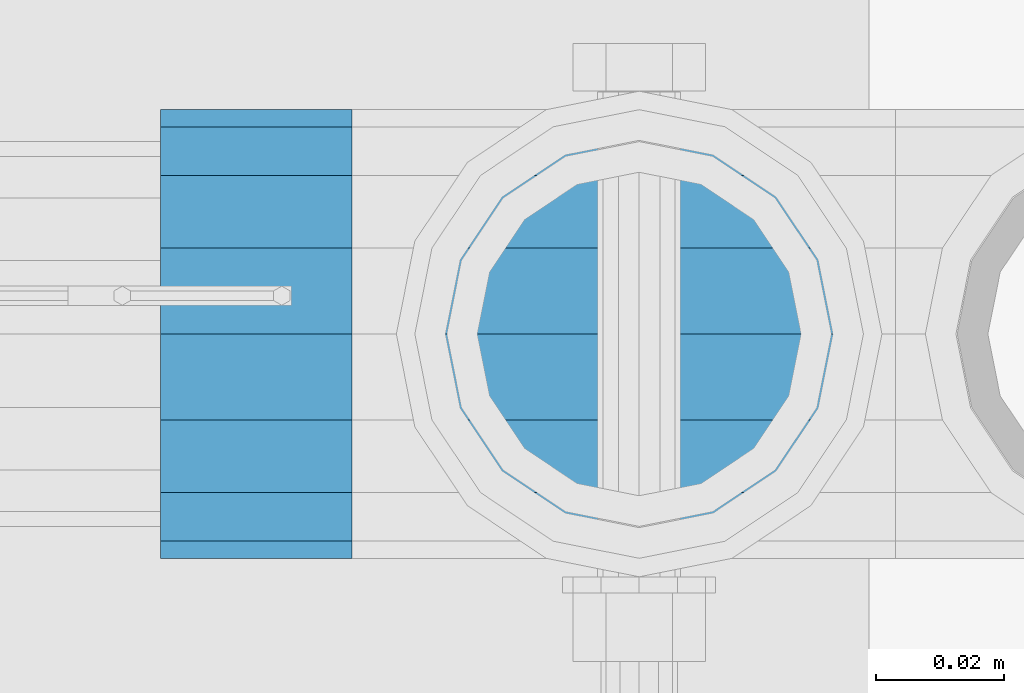
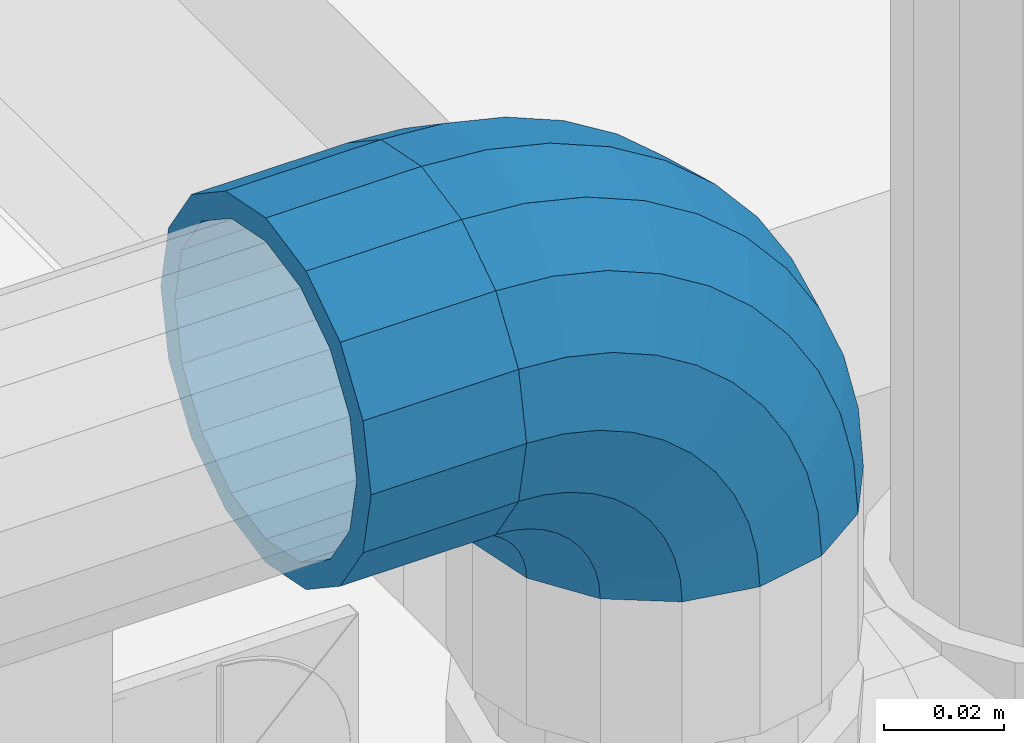
# One storey, part 173 of 247: 1 beam, 1 member.
"""IFC2X3 building model written with IfcOpenShell, lengths in millimetres."""

import ifcopenshell
import ifcopenshell.guid

model = None  # the IFC model being written
_history = None  # IfcOwnerHistory: only IFC2X3 demands one
_inside = {}  # id of a spatial element -> (the spatial element, [elements in it])
_under = {}  # id of a project, library or spatial element -> (it, [spatial elements below it])
_declared = {}  # id of a project -> (the project, [libraries it declares])
_typed = {}  # id of a type object -> (the type object, [elements of that type])
_made_of = {}  # id of a material, layer set ... -> (it, [elements and type objects made of it])


def new_model(schema):
    """Start an empty IFC model of exactly this schema.

    Asked for "IFC4X3", IfcOpenShell would pick the latest addendum, in which some entities
    have other attributes; the version numbers below select the first issue.
    IFC2X3 requires an IfcOwnerHistory on every rooted entity: one is made here for all.
    """
    global model, _history
    if schema == "IFC4X3":
        model = ifcopenshell.file(schema_version=(4, 3, 0, 0))
    else:
        model = ifcopenshell.file(schema=schema)
    _inside.clear()
    _under.clear()
    _declared.clear()
    _typed.clear()
    _made_of.clear()
    _history = None
    if model.schema == "IFC2X3":
        org = make("IfcOrganization", Name="unknown")
        user = make(
            "IfcPersonAndOrganization",
            ThePerson=make("IfcPerson", FamilyName="unknown"),
            TheOrganization=org,
        )
        app = make(
            "IfcApplication",
            ApplicationDeveloper=org,
            Version="unknown",
            ApplicationFullName="unknown",
            ApplicationIdentifier="unknown",
        )
        _history = make(
            "IfcOwnerHistory",
            OwningUser=user,
            OwningApplication=app,
            ChangeAction="ADDED",
            CreationDate=0,
        )
    return model


def make(cls, **values):
    """One entity of the class cls with the attributes given. An attribute that is None is left unset."""
    return model.create_entity(
        cls, **{name: value for name, value in values.items() if value is not None}
    )


def rooted(cls, **values):
    """An entity with a GlobalId (a new one), such as an element, a storey or a relation."""
    return make(cls, GlobalId=ifcopenshell.guid.new(), OwnerHistory=_history, **values)


def si_unit(unit_type, name, prefix=None):
    """IfcSIUnit, for example si_unit("LENGTHUNIT", "METRE", prefix="MILLI")."""
    return make("IfcSIUnit", UnitType=unit_type, Prefix=prefix, Name=name)


def assignment(units):
    """IfcUnitAssignment: the units of a project."""
    return None if units is None else make("IfcUnitAssignment", Units=units)


def point(xyz):
    """IfcCartesianPoint."""
    return None if xyz is None else make("IfcCartesianPoint", Coordinates=xyz)


def direction(xyz):
    """IfcDirection."""
    return None if xyz is None else make("IfcDirection", DirectionRatios=xyz)


def frame(location, z_axis=None, x_axis=None):
    """IfcAxis2Placement3D, a coordinate frame: its origin and axes. An axis left out is left unset."""
    return make(
        "IfcAxis2Placement3D",
        Location=point(location),
        Axis=direction(z_axis),
        RefDirection=direction(x_axis),
    )


def origin_with_axes():
    """The frame at (0, 0, 0) with the z axis (0, 0, 1) and the x axis (1, 0, 0) written out."""
    return frame((0.0, 0.0, 0.0), z_axis=(0.0, 0.0, 1.0), x_axis=(1.0, 0.0, 0.0))


def place(relative_to, where):
    """IfcLocalPlacement: puts the frame where relative to a parent placement (None: the world)."""
    return make(
        "IfcLocalPlacement", PlacementRelTo=relative_to, RelativePlacement=where
    )


def context(
    kind, dimensions, precision=None, world=None, true_north=None, identifier=None
):
    """IfcGeometricRepresentationContext, for example the 3D "Model" context."""
    return make(
        "IfcGeometricRepresentationContext",
        ContextIdentifier=identifier,
        ContextType=kind,
        CoordinateSpaceDimension=dimensions,
        Precision=precision,
        WorldCoordinateSystem=world,
        TrueNorth=true_north,
    )


def subcontext(parent, identifier, kind, view, scale=None):
    """IfcGeometricRepresentationSubContext, for example "Body" below "Model"."""
    return make(
        "IfcGeometricRepresentationSubContext",
        ContextIdentifier=identifier,
        ContextType=kind,
        ParentContext=parent,
        TargetScale=scale,
        TargetView=view,
    )


def project(units=None, contexts=None):
    """IfcProject with its units and contexts."""
    return rooted(
        "IfcProject",
        Name="project",
        RepresentationContexts=contexts,
        UnitsInContext=assignment(units),
    )


def spatial(cls, under=None, at=None, **own):
    """A site, building, storey or space (cls), placed at a placement, below another one or the project."""
    s = rooted(cls, ObjectPlacement=at, **own)
    if under is not None:
        _under.setdefault(under.id(), (under, []))[1].append(s)
    return s


def faces_of(points, faces, orient=None, outer=None):
    """IfcFace entities. A face is a list of loops; a loop is a list of indices into points, from 0.

    orient and outer hold one flag for each loop. By default every Orientation is true, the
    first loop of a face is its IfcFaceOuterBound and the others are IfcFaceBound.
    """
    made = []
    for i, loops in enumerate(faces):
        bounds = []
        for j, loop in enumerate(loops):
            is_outer = j == 0 if outer is None else outer[i][j]
            bounds.append(
                make(
                    "IfcFaceOuterBound" if is_outer else "IfcFaceBound",
                    Bound=make("IfcPolyLoop", Polygon=[points[k] for k in loop]),
                    Orientation=True if orient is None else orient[i][j],
                )
            )
        made.append(make("IfcFace", Bounds=bounds))
    return made


def faceted_brep(points, faces, orient=None, outer=None, voids=None):
    """IfcFacetedBrep: a solid bounded by flat faces; with voids (closed shells), ...WithVoids."""
    shared = [point(p) for p in points]
    hull = make("IfcClosedShell", CfsFaces=faces_of(shared, faces, orient, outer))
    if voids is None:
        return make("IfcFacetedBrep", Outer=hull)
    return make(
        "IfcFacetedBrepWithVoids",
        Outer=hull,
        Voids=[
            make(cls, CfsFaces=faces_of(shared, fs, o, b)) for cls, fs, o, b in voids
        ],
    )


def shape(context_of_items, identifier, shape_type, items):
    """IfcShapeRepresentation: the items that make up one representation, for example the "Body"."""
    return make(
        "IfcShapeRepresentation",
        ContextOfItems=context_of_items,
        RepresentationIdentifier=identifier,
        RepresentationType=shape_type,
        Items=items,
    )


def material(Name=None, Category=None):
    """IfcMaterial."""
    return make("IfcMaterial", Name=Name, Category=Category)


def made_of(thing, what):
    """Note that an element or type object is made of a material, layer set ...; save() writes the relation."""
    if what is not None:
        _made_of.setdefault(what.id(), (what, []))[1].append(thing)
    return thing


def type_object(cls, material=None, **own):
    """A type object (cls), such as IfcWallType, which elements share."""
    return made_of(rooted(cls, **own), material)


def element(
    cls,
    number,
    at=None,
    inside=None,
    cuts=None,
    type_object=None,
    material=None,
    context=None,
    identifier="Body",
    shape_type=None,
    held_by="IfcProductDefinitionShape",
    body=None,
    shapes=None,
    **own,
):
    """One element of the class cls, such as IfcWall. Its Tag is "e" and its number.

    at: its placement. inside: the storey or other place that contains it. cuts: it is an
    opening in that element (IfcRelVoidsElement). A single representation is given by context,
    identifier, shape_type and body (its items); several are given by shapes. held_by: the class
    of the entity that holds the representations. save() writes the other relations.
    """
    e = rooted(cls, Tag="e%d" % number, ObjectPlacement=at, **own)
    if body is not None:
        shapes = [shape(context, identifier, shape_type, body)]
    if shapes is not None:
        e.Representation = make(held_by, Representations=shapes)
    if inside is not None:
        _inside.setdefault(inside.id(), (inside, []))[1].append(e)
    if cuts is not None:
        rooted(
            "IfcRelVoidsElement", RelatingBuildingElement=cuts, RelatedOpeningElement=e
        )
    if type_object is not None:
        _typed.setdefault(type_object.id(), (type_object, []))[1].append(e)
    return made_of(e, material)


def aggregate(whole, parts):
    """IfcRelAggregates: a whole, such as a stair, and the parts it consists of."""
    return rooted("IfcRelAggregates", RelatingObject=whole, RelatedObjects=parts)


def save(model, path):
    """Write the relations noted so far, then the file.

    IfcRelAggregates (storeys below a building ...), IfcRelContainedInSpatialStructure (elements
    in a storey), IfcRelDefinesByType, IfcRelAssociatesMaterial and IfcRelDeclares: one each for
    every whole, place, type object, material and project.
    """
    for whole, parts in _under.values():
        aggregate(whole, parts)
    for where, things in _inside.values():
        rooted(
            "IfcRelContainedInSpatialStructure",
            RelatedElements=things,
            RelatingStructure=where,
        )
    for kind, things in _typed.values():
        rooted("IfcRelDefinesByType", RelatedObjects=things, RelatingType=kind)
    for what, things in _made_of.values():
        rooted("IfcRelAssociatesMaterial", RelatedObjects=things, RelatingMaterial=what)
    for by, libraries in _declared.values():
        rooted("IfcRelDeclares", RelatingContext=by, RelatedDefinitions=libraries)
    model.write(path)


model = new_model("IFC2X3")

# Units and contexts
model_context = context("Model", 3, precision=1e-05, world=origin_with_axes())
body_context = subcontext(model_context, "Body", "Model", "MODEL_VIEW")
ifc_project = project(units=[si_unit("LENGTHUNIT", "METRE", prefix="MILLI"), si_unit("AREAUNIT", "SQUARE_METRE"), si_unit("VOLUMEUNIT", "CUBIC_METRE"), si_unit("MASSUNIT", "GRAM", prefix="KILO"), si_unit("TIMEUNIT", "SECOND"), si_unit("PLANEANGLEUNIT", "RADIAN"), si_unit("SOLIDANGLEUNIT", "STERADIAN"), si_unit("THERMODYNAMICTEMPERATUREUNIT", "DEGREE_CELSIUS"), si_unit("LUMINOUSINTENSITYUNIT", "LUMEN")], contexts=[model_context])

# Site, building, storey
site_placement = place(None, origin_with_axes())
site = spatial("IfcSite", under=ifc_project, at=site_placement, CompositionType="ELEMENT")
building_placement = place(site_placement, origin_with_axes())
building = spatial("IfcBuilding", under=site, at=building_placement, Name="Standard", CompositionType="ELEMENT")
storey_placement = place(building_placement, origin_with_axes())
storey = spatial("IfcBuildingStorey", under=building, at=storey_placement, Name="Undefined", CompositionType="ELEMENT", Elevation=0.0)

# Beam
ifc_material = material(Name="Misc_Undefined")
beam_type = type_object("IfcBeamType", PredefinedType="NOTDEFINED")
beam_placement = place(storey_placement, frame((16176.0, 7664.5, 969.85), z_axis=(0.0, 0.0, 1.0), x_axis=(-1.0, 0.0, 0.0)))
element("IfcBeam", 1, at=beam_placement, inside=storey, type_object=beam_type, material=ifc_material, context=body_context, shape_type="Brep", body=[
    faceted_brep([(0.0, -30.3500000000004, 0.0), (0.0, -28.0397438117179, 11.6144421722802), (30.0, -28.0397438117179, 11.6144421722805), (30.0, -30.3500000000004, 0.0), (0.0, -21.4606908090118, 21.4606908090118), (30.0, -21.4606908090118, 21.4606908090117), (0.0, -11.6144421722802, 28.0397438117179), (30.0, -11.6144421722802, 28.0397438117175), (0.0, 0.0, 30.3500000000004), (30.0, 0.0, 30.35), (0.0, 11.6144421722802, 28.0397438117179), (30.0, 11.6144421722802, 28.0397438117175), (0.0, 21.4606908090118, 21.4606908090118), (30.0, 21.4606908090118, 21.4606908090117), (0.0, 28.0397438117179, 11.6144421722802), (30.0, 28.0397438117179, 11.6144421722805), (0.0, 30.3500000000004, 0.0), (30.0, 30.3500000000004, 0.0), (0.0, 28.0397438117179, -11.6144421722802), (30.0, 28.0397438117179, -11.6144421722805), (0.0, 21.4606908090118, -21.4606908090118), (30.0, 21.4606908090118, -21.4606908090117), (0.0, 11.6144421722802, -28.0397438117179), (30.0, 11.6144421722802, -28.0397438117175), (0.0, 0.0, -30.3500000000004), (30.0, 0.0, -30.35), (0.0, -11.6144421722802, -28.0397438117179), (30.0, -11.6144421722802, -28.0397438117175), (0.0, -21.4606908090118, -21.4606908090118), (30.0, -21.4606908090118, -21.4606908090117), (0.0, -28.0397438117179, -11.6144421722802), (30.0, -28.0397438117179, -11.6144421722805), (0.0, -35.1499999999996, 0.0), (0.0, -32.4743655677721, -13.4513226476338), (30.0, -32.4743655677721, -13.4513226476329), (30.0, -35.1499999999996, 0.0), (0.0, -24.8548033587067, -24.8548033587067), (30.0, -24.8548033587067, -24.8548033587072), (0.0, -13.4513226476329, -32.4743655677721), (30.0, -13.4513226476329, -32.4743655677717), (0.0, 0.0, -35.1499999999996), (30.0, 0.0, -35.15), (0.0, 13.4513226476329, -32.4743655677721), (30.0, 13.4513226476329, -32.4743655677717), (0.0, 24.8548033587067, -24.8548033587067), (30.0, 24.8548033587067, -24.8548033587072), (0.0, 32.4743655677721, -13.4513226476338), (30.0, 32.4743655677721, -13.4513226476329), (0.0, 35.1499999999996, 0.0), (30.0, 35.1499999999996, 0.0), (0.0, 32.4743655677721, 13.4513226476338), (30.0, 32.4743655677721, 13.4513226476329), (0.0, 24.8548033587067, 24.8548033587067), (30.0, 24.8548033587067, 24.8548033587072), (0.0, 13.4513226476329, 32.4743655677721), (30.0, 13.4513226476329, 32.4743655677717), (0.0, 0.0, 35.1499999999996), (30.0, 0.0, 35.15), (0.0, -13.4513226476329, 32.4743655677721), (30.0, -13.4513226476329, 32.4743655677717), (0.0, -24.8548033587067, 24.8548033587067), (30.0, -24.8548033587067, 24.8548033587072), (0.0, -32.4743655677721, 13.4513226476338), (30.0, -32.4743655677721, 13.4513226476329)], [[[0, 1, 2, 3]], [[1, 4, 5, 2]], [[4, 6, 7, 5]], [[6, 8, 9, 7]], [[8, 10, 11, 9]], [[10, 12, 13, 11]], [[12, 14, 15, 13]], [[14, 16, 17, 15]], [[16, 18, 19, 17]], [[18, 20, 21, 19]], [[20, 22, 23, 21]], [[22, 24, 25, 23]], [[24, 26, 27, 25]], [[26, 28, 29, 27]], [[28, 30, 31, 29]], [[30, 0, 3, 31]], [[32, 33, 34, 35]], [[33, 36, 37, 34]], [[36, 38, 39, 37]], [[38, 40, 41, 39]], [[40, 42, 43, 41]], [[42, 44, 45, 43]], [[44, 46, 47, 45]], [[46, 48, 49, 47]], [[48, 50, 51, 49]], [[50, 52, 53, 51]], [[52, 54, 55, 53]], [[54, 56, 57, 55]], [[56, 58, 59, 57]], [[58, 60, 61, 59]], [[60, 62, 63, 61]], [[62, 32, 35, 63]], [[37, 39, 41, 43, 45, 47, 49, 51, 53, 55, 57, 59, 61, 63, 35, 34], [5, 7, 9, 11, 13, 15, 17, 19, 21, 23, 25, 27, 29, 31, 3, 2]], [[62, 60, 58, 56, 54, 52, 50, 48, 46, 44, 42, 40, 38, 36, 33, 32], [30, 28, 26, 24, 22, 20, 18, 16, 14, 12, 10, 8, 6, 4, 1, 0]]]),
])

# Member
member_type = type_object("IfcMemberType", PredefinedType="NOTDEFINED")
member_placement = place(storey_placement, frame((16221.0, 7664.5, 924.85), z_axis=(0.707106781186548, 0.0, 0.707106781186547), x_axis=(-0.707106789186492, 3.85000008583224e-07, 0.707106773186498)))
element("IfcMember", 2, at=member_placement, inside=storey, type_object=member_type, material=ifc_material, context=body_context, shape_type="Brep", body=[
    faceted_brep([(0.0, -35.1499999999996, 0.0), (9.51152146007007, -32.4743655677721, -9.51152146007007), (13.2759578763416, -32.4743655677721, -6.29638902527768), (5.36946880023424, -35.1499999999996, 4.58595959347804), (17.5750000000007, -24.8548033587067, -17.5750000000007), (19.9787556631127, -24.8548033587067, -15.5219987155633), (22.9628441077039, -13.4513226476329, -22.962844107702), (24.4574219585265, -13.4513226476329, -21.6863540323957), (24.8548033587067, 0.0, -24.8548033587067), (26.0301204183143, 0.0, -23.8509877588021), (22.9628441077039, 13.4513226476329, -22.962844107702), (24.4574219585265, 13.4513226476329, -21.6863540323957), (17.5750000000007, 24.8548033587067, -17.5750000000007), (19.9787556631127, 24.8548033587067, -15.5219987155633), (9.51152146007007, 32.4743655677721, -9.51152146007007), (13.2759578763416, 32.4743655677721, -6.29638902527768), (0.0, 35.1499999999996, 0.0), (5.36946880023424, 35.1499999999996, 4.58595959347804), (-9.51152146007007, 32.4743655677721, 9.51152146007007), (-2.53702027587133, 32.4743655677721, 15.4683082122338), (-17.5749999999989, 24.8548033587067, 17.5749999999989), (-9.23981806264237, 24.8548033587067, 24.6939179025194), (-22.962844107702, 13.4513226476329, 22.962844107702), (-13.718484358058, 13.4513226476329, 30.8582732193499), (-24.8548033587067, 0.0, 24.8548033587067), (-15.2911828178458, 0.0, 33.0229069457564), (-22.962844107702, -13.4513226476329, 22.962844107702), (-13.718484358058, -13.4513226476329, 30.8582732193499), (-17.5749999999989, -24.8548033587067, 17.5749999999989), (-9.23981806264237, -24.8548033587067, 24.6939179025194), (-9.51152146007007, -32.4743655677721, 9.51152146007007), (-2.53702027587133, -32.4743655677721, 15.4683082122338), (0.0, -30.3500000000004, 0.0), (-8.21265081971796, -28.0397438117179, 8.21265081971796), (-1.45732902223608, -28.0397438117179, 13.9822406910371), (5.36946880023424, -30.3500000000004, 4.58595959347804), (-15.1749999999993, -21.4606908090118, 15.1749999999993), (-7.24480876131202, -21.4606908090118, 21.948023168994), (-19.8270929919981, -11.6144421722802, 19.827092992), (-11.1118790903529, -11.6144421722802, 27.2705888550772), (-21.4606908090118, 0.0, 21.4606908090118), (-12.4698136068437, 0.0, 29.139625372758), (-19.8270929919981, 11.6144421722802, 19.827092992), (-11.1118790903529, 11.6144421722802, 27.2705888550772), (-15.1749999999993, 21.4606908090118, 15.1749999999993), (-7.24480876131202, 21.4606908090118, 21.948023168994), (-8.21265081971796, 28.0397438117179, 8.21265081971796), (-1.45732902223608, 28.0397438117179, 13.9822406910371), (0.0, 30.3500000000004, 0.0), (5.36946880023424, 30.3500000000004, 4.58595959347804), (8.21265081971978, 28.0397438117179, -8.21265081971796), (12.1962666227046, 28.0397438117179, -4.81032150408282), (15.1750000000011, 21.4606908090118, -15.1750000000011), (17.9837463617787, 21.4606908090118, -12.776103982038), (19.827092992, 11.6144421722802, -19.827092992), (21.8508166908214, 11.6144421722802, -18.0986696681211), (21.4606908090118, 0.0, -21.4606908090118), (23.2087512073122, 0.0, -19.9677061858038), (19.827092992, -11.6144421722802, -19.827092992), (21.8508166908214, -11.6144421722802, -18.0986696681211), (15.1750000000011, -21.4606908090118, -15.1750000000011), (17.9837463617787, -21.4606908090118, -12.776103982038), (8.21265081971978, -28.0397438117179, -8.21265081971796), (12.1962666227046, -28.0397438117179, -4.81032150408282), (17.4970053560719, -32.4743655677721, -3.70972780292141), (11.3902326651169, -35.1499999999996, 8.27548843508157), (22.6740772628636, -24.8548033587067, -13.8703035149447), (26.1332861179544, -13.4513226476329, -20.6593831546816), (27.347998730962, 0.0, -23.0433908901377), (26.1332861179544, 13.4513226476329, -20.6593831546816), (22.6740772628636, 24.8548033587067, -13.8703035149447), (17.4970053560719, 32.4743655677721, -3.70972780292141), (11.3902326651169, 35.1499999999996, 8.27548843508157), (5.28345997416, 32.4743655677721, 20.2607046730845), (0.106388067368243, 24.8548033587067, 30.4212803851096), (-3.3528207877207, 13.4513226476329, 37.2103600248429), (-4.56753340072828, 0.0, 39.5943677603027), (-3.3528207877207, -13.4513226476329, 37.2103600248429), (0.106388067368243, -24.8548033587067, 30.4212803851096), (5.28345997416, -32.4743655677721, 20.2607046730845), (6.11738625912767, -28.0397438117179, 18.6240321853929), (11.3902326651169, -30.3500000000004, 8.27548843508157), (1.64728291997744, -21.4606908090118, 27.3971039594999), (-1.33954464053386, -11.6144421722802, 33.2590831078905), (-2.38837900197905, 0.0, 35.3175364441977), (-1.33954464053386, 11.6144421722802, 33.2590831078905), (1.64728291997744, 21.4606908090118, 27.3971039594999), (6.11738625912767, 28.0397438117179, 18.6240321853929), (11.3902326651169, 30.3500000000004, 8.27548843508157), (16.663079071106, 28.0397438117179, -2.07305531522979), (21.1331824102544, 21.4606908090118, -10.8461270893367), (24.1200099707676, 11.6144421722802, -16.7081062377292), (25.1688443322109, 0.0, -18.7665595740345), (24.1200099707676, -11.6144421722802, -16.7081062377292), (21.1331824102544, -21.4606908090118, -10.8461270893367), (16.663079071106, -28.0397438117179, -2.07305531522979), (22.0707277014626, -32.4743655677721, -1.81522997693355), (17.9140404065238, -35.1499999999996, 10.9777380798878), (25.5945970362118, -24.8548033587067, -12.6605846156472), (27.9491712485105, -13.4513226476329, -19.9072189058952), (28.7759877588032, 0.0, -22.4518984678889), (27.9491712485105, 13.4513226476329, -19.9072189058952), (25.5945970362118, 24.8548033587067, -12.6605846156472), (22.0707277014626, 32.4743655677721, -1.81522997693355), (17.9140404065238, 35.1499999999996, 10.9777380798878), (13.757353111585, 32.4743655677721, 23.7707061367073), (10.2334837768358, 24.8548033587067, 34.6160607754209), (7.87890956453703, 13.4513226476329, 41.8626950656671), (7.05209305424432, 0.0, 44.4073746276608), (7.87890956453703, -13.4513226476329, 41.8626950656671), (10.2334837768358, -24.8548033587067, 34.6160607754209), (13.757353111585, -32.4743655677721, 23.7707061367073), (14.3249803951039, -28.0397438117179, 22.0237289909692), (17.9140404065238, -30.3500000000004, 10.9777380798878), (11.2823222355109, -21.4606908090118, 31.3880679179929), (9.24928305078174, -11.6144421722802, 37.6451191472679), (8.53537462724307, 0.0, 39.8423033494455), (9.24928305078174, 11.6144421722802, 37.6451191472679), (11.2823222355109, 21.4606908090118, 31.3880679179929), (14.3249803951039, 28.0397438117179, 22.0237289909692), (17.9140404065238, 30.3500000000004, 10.9777380798878), (21.5031004179418, 28.0397438117179, -0.0682528311936039), (24.5457585775348, 21.4606908090118, -9.43259175821731), (26.578797762264, 11.6144421722802, -15.6896429874942), (27.2927061858027, 0.0, -17.8868271896699), (26.578797762264, -11.6144421722802, -15.6896429874942), (24.5457585775348, -21.4606908090118, -9.43259175821731), (21.5031004179418, -28.0397438117179, -0.0682528311936039), (26.884504689051, -32.4743655677721, -0.65954437126311), (24.7802542265854, -35.1499999999996, 12.6261701733856), (28.6684020936846, -24.8548033587067, -11.9226293117936), (29.8603642317012, -13.4513226476329, -19.4483820661262), (30.2789256727501, 0.0, -22.0910749985342), (29.8603642317012, 13.4513226476329, -19.4483820661262), (28.6684020936846, 24.8548033587067, -11.9226293117936), (26.884504689051, 32.4743655677721, -0.65954437126311), (24.7802542265854, 35.1499999999996, 12.6261701733856), (22.6760037641197, 32.4743655677721, 25.9118847180362), (20.8921063594862, 24.8548033587067, 37.1749696585666), (19.7001442214696, 13.4513226476329, 44.7007224128993), (19.2815827804206, 0.0, 47.3434153453054), (19.7001442214696, -13.4513226476329, 44.7007224128993), (20.8921063594862, -24.8548033587067, 37.1749696585666), (22.6760037641197, -32.4743655677721, 25.9118847180362), (22.9633551786228, -28.0397438117179, 24.097619289465), (24.7802542265854, -30.3500000000004, 12.6261701733856), (21.4230625404816, -21.4606908090118, 33.8226442665655), (20.3938719035341, -11.6144421722802, 40.3206982094944), (20.0324682126138, 0.0, 42.6025113104479), (20.3938719035341, 11.6144421722802, 40.3206982094944), (21.4230625404816, 21.4606908090118, 33.8226442665655), (22.9633551786228, 28.0397438117179, 24.097619289465), (24.7802542265854, 30.3500000000004, 12.6261701733856), (26.5971532745461, 28.0397438117179, 1.15472105730987), (28.1374459126855, 21.4606908090118, -8.5703039197906), (29.1666365496367, 11.6144421722802, -15.0683578627213), (29.5280402405569, 0.0, -17.3501709636766), (29.1666365496367, -11.6144421722802, -15.0683578627213), (28.1374459126855, -21.4606908090118, -8.5703039197906), (26.5971532745461, -28.0397438117179, 1.15472105730987), (31.8198051533964, -32.4743655677721, -0.271127801028342), (31.8198051533946, -35.1499999999996, 13.1801948466054), (31.8198051533964, -24.8548033587067, -11.6746085121031), (31.8198051533964, -13.4513226476329, -19.2941707211648), (31.8198051533964, 0.0, -21.969805153396), (31.8198051533964, 13.4513226476329, -19.2941707211648), (31.8198051533964, 24.8548033587067, -11.6746085121031), (31.8198051533964, 32.4743655677721, -0.271127801028342), (31.8198051533946, 35.1499999999996, 13.1801948466054), (31.8198051533946, 32.4743655677721, 26.6315174942392), (31.8198051533946, 24.8548033587067, 38.0349982053121), (31.8198051533964, 13.4513226476329, 45.6545604143757), (31.8198051533964, 0.0, 48.3301948466033), (31.8198051533964, -13.4513226476329, 45.6545604143757), (31.8198051533946, -24.8548033587067, 38.0349982053121), (31.8198051533946, -32.4743655677721, 26.6315174942392), (31.8198051533964, -28.0397438117179, 24.7946370188838), (31.8198051533946, -30.3500000000004, 13.1801948466054), (31.8198051533964, -21.4606908090118, 34.6408856556172), (31.8198051533946, -11.6144421722802, 41.2199386583234), (31.8198051533964, 0.0, 43.530194846604), (31.8198051533946, 11.6144421722802, 41.2199386583234), (31.8198051533964, 21.4606908090118, 34.6408856556172), (31.8198051533964, 28.0397438117179, 24.7946370188838), (31.8198051533946, 30.3500000000004, 13.1801948466054), (31.8198051533964, 28.0397438117179, 1.56575267432345), (31.8198051533964, 21.4606908090118, -8.28049596240635), (31.8198051533946, 11.6144421722802, -14.8595489651125), (31.8198051533964, 0.0, -17.1698051533949), (31.8198051533946, -11.6144421722802, -14.8595489651125), (31.8198051533964, -21.4606908090118, -8.28049596240635), (31.8198051533964, -28.0397438117179, 1.56575267432345), (36.7551056177399, -32.4743655677721, -0.659544371264928), (38.8593560802055, -35.1499999999996, 12.6261701733874), (34.9712082131082, -24.8548033587067, -11.9226293117936), (33.7792460750934, -13.4513226476329, -19.4483820661262), (33.3606846340426, 0.0, -22.0910749985342), (33.7792460750934, 13.4513226476329, -19.4483820661262), (34.9712082131082, 24.8548033587067, -11.9226293117936), (36.7551056177399, 32.4743655677721, -0.659544371264928), (38.8593560802055, 35.1499999999996, 12.6261701733874), (40.963606542673, 32.4743655677721, 25.9118847180362), (42.7475039473047, 24.8548033587067, 37.1749696585666), (43.9394660853195, 13.4513226476329, 44.7007224128993), (44.3580275263703, 0.0, 47.3434153453054), (43.9394660853195, -13.4513226476329, 44.7007224128993), (42.7475039473047, -24.8548033587067, 37.1749696585666), (40.963606542673, -32.4743655677721, 25.9118847180362), (40.6762551281663, -28.0397438117179, 24.097619289465), (38.8593560802055, -30.3500000000004, 12.6261701733874), (42.2165477663093, -21.4606908090118, 33.8226442665637), (43.2457384032587, -11.6144421722802, 40.3206982094925), (43.6071420941771, 0.0, 42.6025113104497), (43.2457384032587, 11.6144421722802, 40.3206982094925), (42.2165477663093, 21.4606908090118, 33.8226442665637), (40.6762551281663, 28.0397438117179, 24.097619289465), (38.8593560802055, 30.3500000000004, 12.6261701733874), (37.0424570322448, 28.0397438117179, 1.15472105730805), (35.5021643941036, 21.4606908090118, -8.5703039197906), (34.4729737571543, 11.6144421722802, -15.0683578627213), (34.1115700662358, 0.0, -17.3501709636766), (34.4729737571543, -11.6144421722802, -15.0683578627213), (35.5021643941036, -21.4606908090118, -8.5703039197906), (37.0424570322448, -28.0397438117179, 1.15472105730805), (41.5688826053301, -32.4743655677721, -1.81522997693355), (45.725569900269, -35.1499999999996, 10.9777380798878), (38.045013270581, -24.8548033587067, -12.6605846156453), (35.6904390582822, -13.4513226476329, -19.9072189058934), (34.8636225479895, 0.0, -22.4518984678889), (35.6904390582822, 13.4513226476329, -19.9072189058934), (38.045013270581, 24.8548033587067, -12.6605846156453), (41.5688826053301, 32.4743655677721, -1.81522997693355), (45.725569900269, 35.1499999999996, 10.9777380798878), (49.8822571952078, 32.4743655677721, 23.7707061367073), (53.406126529957, 24.8548033587067, 34.6160607754209), (55.7607007422539, 13.4513226476329, 41.8626950656671), (56.5875172525484, 0.0, 44.4073746276608), (55.7607007422539, -13.4513226476329, 41.8626950656671), (53.406126529957, -24.8548033587067, 34.6160607754209), (49.8822571952078, -32.4743655677721, 23.7707061367073), (49.3146299116888, -28.0397438117179, 22.0237289909674), (45.725569900269, -30.3500000000004, 10.9777380798878), (52.35728807128, -21.4606908090118, 31.3880679179929), (54.3903272560092, -11.6144421722802, 37.6451191472679), (55.1042356795479, 0.0, 39.8423033494455), (54.3903272560092, 11.6144421722802, 37.6451191472679), (52.35728807128, 21.4606908090118, 31.3880679179929), (49.3146299116888, 28.0397438117179, 22.0237289909674), (45.725569900269, 30.3500000000004, 10.9777380798878), (42.1365098888491, 28.0397438117179, -0.0682528311936039), (39.0938517292579, 21.4606908090118, -9.43259175821913), (37.0608125445287, 11.6144421722802, -15.6896429874942), (36.3469041209901, 0.0, -17.8868271896699), (37.0608125445287, -11.6144421722802, -15.6896429874942), (39.0938517292579, -21.4606908090118, -9.43259175821913), (42.1365098888491, -28.0397438117179, -0.0682528311936039), (46.1426049507172, -32.4743655677721, -3.70972780292141), (52.2493776416759, -35.1499999999996, 8.27548843508157), (40.9655330439273, -24.8548033587067, -13.8703035149447), (37.5063241888383, -13.4513226476329, -20.6593831546816), (36.2916115758308, 0.0, -23.0433908901396), (37.5063241888383, 13.4513226476329, -20.6593831546816), (40.9655330439273, 24.8548033587067, -13.8703035149447), (46.1426049507172, 32.4743655677721, -3.70972780292141), (52.2493776416759, 35.1499999999996, 8.27548843508157), (58.3561503326328, 32.4743655677721, 20.2607046730845), (63.5332222394227, 24.8548033587067, 30.4212803851078), (66.9924310945134, 13.4513226476329, 37.2103600248447), (68.207143707521, 0.0, 39.5943677603027), (66.9924310945134, -13.4513226476329, 37.2103600248447), (63.5332222394227, -24.8548033587067, 30.4212803851078), (58.3561503326328, -32.4743655677721, 20.2607046730845), (57.5222240476651, -28.0397438117179, 18.6240321853929), (52.2493776416759, -30.3500000000004, 8.27548843508157), (61.9923273868153, -21.4606908090118, 27.3971039594999), (64.9791549473266, -11.6144421722802, 33.2590831078905), (66.0279893087718, 0.0, 35.3175364441995), (64.9791549473266, 11.6144421722802, 33.2590831078905), (61.9923273868153, 21.4606908090118, 27.3971039594999), (57.5222240476651, 28.0397438117179, 18.6240321853929), (52.2493776416759, 30.3500000000004, 8.27548843508157), (46.9765312356867, 28.0397438117179, -2.07305531522979), (42.5064278965383, 21.4606908090118, -10.8461270893367), (39.5196003360252, 11.6144421722802, -16.7081062377292), (38.47076597458, 0.0, -18.7665595740345), (39.5196003360252, -11.6144421722802, -16.7081062377292), (42.5064278965383, -21.4606908090118, -10.8461270893367), (46.9765312356867, -28.0397438117179, -2.07305531522979), (50.3636524304511, -32.4743655677721, -6.29638902527768), (58.2701415065567, -35.1499999999996, 4.58595959347804), (43.6608546436782, -24.8548033587067, -15.5219987155633), (39.1821883482662, -13.4513226476329, -21.6863540323939), (37.6094898884767, 0.0, -23.8509877588021), (39.1821883482662, 13.4513226476329, -21.6863540323939), (43.6608546436782, 24.8548033587067, -15.5219987155633), (50.3636524304511, 32.4743655677721, -6.29638902527768), (58.2701415065567, 35.1499999999996, 4.58595959347804), (66.1766305826623, 32.4743655677721, 15.4683082122338), (72.8794283694351, 24.8548033587067, 24.6939179025212), (77.3580946648472, 13.4513226476329, 30.8582732193499), (78.9307931246385, 0.0, 33.0229069457564), (77.3580946648472, -13.4513226476329, 30.8582732193499), (72.8794283694351, -24.8548033587067, 24.6939179025212), (66.1766305826623, -32.4743655677721, 15.4683082122338), (65.096939329027, -28.0397438117179, 13.9822406910371), (58.2701415065567, -30.3500000000004, 4.58595959347804), (70.8844190681029, -21.4606908090118, 21.948023168994), (74.7514893971438, -11.6144421722802, 27.2705888550772), (76.1094239136346, 0.0, 29.139625372758), (74.7514893971438, 11.6144421722802, 27.2705888550772), (70.8844190681029, 21.4606908090118, 21.948023168994), (65.096939329027, 28.0397438117179, 13.9822406910371), (58.2701415065567, 30.3500000000004, 4.58595959347804), (51.4433436840882, 28.0397438117179, -4.810321504081), (45.6558639450104, 21.4606908090118, -12.776103982038), (41.7887936159714, 11.6144421722802, -18.0986696681211), (40.4308590994806, 0.0, -19.9677061858019), (41.7887936159714, -11.6144421722802, -18.0986696681211), (45.6558639450104, -21.4606908090118, -12.776103982038), (51.4433436840882, -28.0397438117179, -4.810321504081), (54.1280888467209, -32.4743655677721, -9.51152146007007), (63.6396103067891, -35.1499999999996, 0.0), (46.0646103067902, -24.8548033587067, -17.5750000000007), (40.6767661990871, -13.4513226476329, -22.962844107702), (38.7848069480824, 0.0, -24.8548033587067), (40.6767661990871, 13.4513226476329, -22.962844107702), (46.0646103067902, 24.8548033587067, -17.5750000000007), (54.1280888467209, 32.4743655677721, -9.51152146007007), (63.6396103067891, 35.1499999999996, 0.0), (73.1511317668592, 32.4743655677721, 9.51152146007007), (81.2146103067898, 24.8548033587067, 17.5750000000007), (86.602454414493, 13.4513226476329, 22.962844107702), (88.4944136654976, 0.0, 24.8548033587067), (86.602454414493, -13.4513226476329, 22.962844107702), (81.2146103067898, -24.8548033587067, 17.5750000000007), (73.1511317668592, -32.4743655677721, 9.51152146007007), (71.8522611265089, -28.0397438117179, 8.21265081971796), (63.6396103067891, -30.3500000000004, 0.0), (78.8146103067902, -21.4606908090118, 15.1749999999993), (83.4667032987891, -11.6144421722802, 19.8270929919981), (85.1003011158009, 0.0, 21.4606908090118), (83.4667032987891, 11.6144421722802, 19.8270929919981), (78.8146103067902, 21.4606908090118, 15.1749999999993), (71.8522611265089, 28.0397438117179, 8.21265081971796), (63.6396103067891, 30.3500000000004, 0.0), (55.4269594870711, 28.0397438117179, -8.21265081971796), (48.4646103067898, 21.4606908090118, -15.1749999999993), (43.812517314791, 11.6144421722802, -19.8270929919981), (42.1789194977791, 0.0, -21.4606908090118), (43.812517314791, -11.6144421722802, -19.8270929919981), (48.4646103067898, -21.4606908090118, -15.1749999999993), (55.4269594870711, -28.0397438117179, -8.21265081971796)], [[[0, 1, 2, 3]], [[1, 4, 5, 2]], [[4, 6, 7, 5]], [[6, 8, 9, 7]], [[8, 10, 11, 9]], [[10, 12, 13, 11]], [[12, 14, 15, 13]], [[14, 16, 17, 15]], [[16, 18, 19, 17]], [[18, 20, 21, 19]], [[20, 22, 23, 21]], [[22, 24, 25, 23]], [[24, 26, 27, 25]], [[26, 28, 29, 27]], [[28, 30, 31, 29]], [[30, 0, 3, 31]], [[32, 33, 34, 35]], [[33, 36, 37, 34]], [[36, 38, 39, 37]], [[38, 40, 41, 39]], [[40, 42, 43, 41]], [[42, 44, 45, 43]], [[44, 46, 47, 45]], [[46, 48, 49, 47]], [[48, 50, 51, 49]], [[50, 52, 53, 51]], [[52, 54, 55, 53]], [[54, 56, 57, 55]], [[56, 58, 59, 57]], [[58, 60, 61, 59]], [[60, 62, 63, 61]], [[62, 32, 35, 63]], [[30, 28, 26, 24, 22, 20, 18, 16, 14, 12, 10, 8, 6, 4, 1, 0], [62, 60, 58, 56, 54, 52, 50, 48, 46, 44, 42, 40, 38, 36, 33, 32]], [[3, 2, 64, 65]], [[2, 5, 66, 64]], [[5, 7, 67, 66]], [[7, 9, 68, 67]], [[9, 11, 69, 68]], [[11, 13, 70, 69]], [[13, 15, 71, 70]], [[15, 17, 72, 71]], [[17, 19, 73, 72]], [[19, 21, 74, 73]], [[21, 23, 75, 74]], [[23, 25, 76, 75]], [[25, 27, 77, 76]], [[27, 29, 78, 77]], [[29, 31, 79, 78]], [[31, 3, 65, 79]], [[35, 34, 80, 81]], [[34, 37, 82, 80]], [[37, 39, 83, 82]], [[39, 41, 84, 83]], [[41, 43, 85, 84]], [[43, 45, 86, 85]], [[45, 47, 87, 86]], [[47, 49, 88, 87]], [[49, 51, 89, 88]], [[51, 53, 90, 89]], [[53, 55, 91, 90]], [[55, 57, 92, 91]], [[57, 59, 93, 92]], [[59, 61, 94, 93]], [[61, 63, 95, 94]], [[63, 35, 81, 95]], [[65, 64, 96, 97]], [[64, 66, 98, 96]], [[66, 67, 99, 98]], [[67, 68, 100, 99]], [[68, 69, 101, 100]], [[69, 70, 102, 101]], [[70, 71, 103, 102]], [[71, 72, 104, 103]], [[72, 73, 105, 104]], [[73, 74, 106, 105]], [[74, 75, 107, 106]], [[75, 76, 108, 107]], [[76, 77, 109, 108]], [[77, 78, 110, 109]], [[78, 79, 111, 110]], [[79, 65, 97, 111]], [[81, 80, 112, 113]], [[80, 82, 114, 112]], [[82, 83, 115, 114]], [[83, 84, 116, 115]], [[84, 85, 117, 116]], [[85, 86, 118, 117]], [[86, 87, 119, 118]], [[87, 88, 120, 119]], [[88, 89, 121, 120]], [[89, 90, 122, 121]], [[90, 91, 123, 122]], [[91, 92, 124, 123]], [[92, 93, 125, 124]], [[93, 94, 126, 125]], [[94, 95, 127, 126]], [[95, 81, 113, 127]], [[97, 96, 128, 129]], [[96, 98, 130, 128]], [[98, 99, 131, 130]], [[99, 100, 132, 131]], [[100, 101, 133, 132]], [[101, 102, 134, 133]], [[102, 103, 135, 134]], [[103, 104, 136, 135]], [[104, 105, 137, 136]], [[105, 106, 138, 137]], [[106, 107, 139, 138]], [[107, 108, 140, 139]], [[108, 109, 141, 140]], [[109, 110, 142, 141]], [[110, 111, 143, 142]], [[111, 97, 129, 143]], [[113, 112, 144, 145]], [[112, 114, 146, 144]], [[114, 115, 147, 146]], [[115, 116, 148, 147]], [[116, 117, 149, 148]], [[117, 118, 150, 149]], [[118, 119, 151, 150]], [[119, 120, 152, 151]], [[120, 121, 153, 152]], [[121, 122, 154, 153]], [[122, 123, 155, 154]], [[123, 124, 156, 155]], [[124, 125, 157, 156]], [[125, 126, 158, 157]], [[126, 127, 159, 158]], [[127, 113, 145, 159]], [[129, 128, 160, 161]], [[128, 130, 162, 160]], [[130, 131, 163, 162]], [[131, 132, 164, 163]], [[132, 133, 165, 164]], [[133, 134, 166, 165]], [[134, 135, 167, 166]], [[135, 136, 168, 167]], [[136, 137, 169, 168]], [[137, 138, 170, 169]], [[138, 139, 171, 170]], [[139, 140, 172, 171]], [[140, 141, 173, 172]], [[141, 142, 174, 173]], [[142, 143, 175, 174]], [[143, 129, 161, 175]], [[145, 144, 176, 177]], [[144, 146, 178, 176]], [[146, 147, 179, 178]], [[147, 148, 180, 179]], [[148, 149, 181, 180]], [[149, 150, 182, 181]], [[150, 151, 183, 182]], [[151, 152, 184, 183]], [[152, 153, 185, 184]], [[153, 154, 186, 185]], [[154, 155, 187, 186]], [[155, 156, 188, 187]], [[156, 157, 189, 188]], [[157, 158, 190, 189]], [[158, 159, 191, 190]], [[159, 145, 177, 191]], [[161, 160, 192, 193]], [[160, 162, 194, 192]], [[162, 163, 195, 194]], [[163, 164, 196, 195]], [[164, 165, 197, 196]], [[165, 166, 198, 197]], [[166, 167, 199, 198]], [[167, 168, 200, 199]], [[168, 169, 201, 200]], [[169, 170, 202, 201]], [[170, 171, 203, 202]], [[171, 172, 204, 203]], [[172, 173, 205, 204]], [[173, 174, 206, 205]], [[174, 175, 207, 206]], [[175, 161, 193, 207]], [[177, 176, 208, 209]], [[176, 178, 210, 208]], [[178, 179, 211, 210]], [[179, 180, 212, 211]], [[180, 181, 213, 212]], [[181, 182, 214, 213]], [[182, 183, 215, 214]], [[183, 184, 216, 215]], [[184, 185, 217, 216]], [[185, 186, 218, 217]], [[186, 187, 219, 218]], [[187, 188, 220, 219]], [[188, 189, 221, 220]], [[189, 190, 222, 221]], [[190, 191, 223, 222]], [[191, 177, 209, 223]], [[193, 192, 224, 225]], [[192, 194, 226, 224]], [[194, 195, 227, 226]], [[195, 196, 228, 227]], [[196, 197, 229, 228]], [[197, 198, 230, 229]], [[198, 199, 231, 230]], [[199, 200, 232, 231]], [[200, 201, 233, 232]], [[201, 202, 234, 233]], [[202, 203, 235, 234]], [[203, 204, 236, 235]], [[204, 205, 237, 236]], [[205, 206, 238, 237]], [[206, 207, 239, 238]], [[207, 193, 225, 239]], [[209, 208, 240, 241]], [[208, 210, 242, 240]], [[210, 211, 243, 242]], [[211, 212, 244, 243]], [[212, 213, 245, 244]], [[213, 214, 246, 245]], [[214, 215, 247, 246]], [[215, 216, 248, 247]], [[216, 217, 249, 248]], [[217, 218, 250, 249]], [[218, 219, 251, 250]], [[219, 220, 252, 251]], [[220, 221, 253, 252]], [[221, 222, 254, 253]], [[222, 223, 255, 254]], [[223, 209, 241, 255]], [[225, 224, 256, 257]], [[224, 226, 258, 256]], [[226, 227, 259, 258]], [[227, 228, 260, 259]], [[228, 229, 261, 260]], [[229, 230, 262, 261]], [[230, 231, 263, 262]], [[231, 232, 264, 263]], [[232, 233, 265, 264]], [[233, 234, 266, 265]], [[234, 235, 267, 266]], [[235, 236, 268, 267]], [[236, 237, 269, 268]], [[237, 238, 270, 269]], [[238, 239, 271, 270]], [[239, 225, 257, 271]], [[241, 240, 272, 273]], [[240, 242, 274, 272]], [[242, 243, 275, 274]], [[243, 244, 276, 275]], [[244, 245, 277, 276]], [[245, 246, 278, 277]], [[246, 247, 279, 278]], [[247, 248, 280, 279]], [[248, 249, 281, 280]], [[249, 250, 282, 281]], [[250, 251, 283, 282]], [[251, 252, 284, 283]], [[252, 253, 285, 284]], [[253, 254, 286, 285]], [[254, 255, 287, 286]], [[255, 241, 273, 287]], [[257, 256, 288, 289]], [[256, 258, 290, 288]], [[258, 259, 291, 290]], [[259, 260, 292, 291]], [[260, 261, 293, 292]], [[261, 262, 294, 293]], [[262, 263, 295, 294]], [[263, 264, 296, 295]], [[264, 265, 297, 296]], [[265, 266, 298, 297]], [[266, 267, 299, 298]], [[267, 268, 300, 299]], [[268, 269, 301, 300]], [[269, 270, 302, 301]], [[270, 271, 303, 302]], [[271, 257, 289, 303]], [[273, 272, 304, 305]], [[272, 274, 306, 304]], [[274, 275, 307, 306]], [[275, 276, 308, 307]], [[276, 277, 309, 308]], [[277, 278, 310, 309]], [[278, 279, 311, 310]], [[279, 280, 312, 311]], [[280, 281, 313, 312]], [[281, 282, 314, 313]], [[282, 283, 315, 314]], [[283, 284, 316, 315]], [[284, 285, 317, 316]], [[285, 286, 318, 317]], [[286, 287, 319, 318]], [[287, 273, 305, 319]], [[289, 288, 320, 321]], [[288, 290, 322, 320]], [[290, 291, 323, 322]], [[291, 292, 324, 323]], [[292, 293, 325, 324]], [[293, 294, 326, 325]], [[294, 295, 327, 326]], [[295, 296, 328, 327]], [[296, 297, 329, 328]], [[297, 298, 330, 329]], [[298, 299, 331, 330]], [[299, 300, 332, 331]], [[300, 301, 333, 332]], [[301, 302, 334, 333]], [[302, 303, 335, 334]], [[303, 289, 321, 335]], [[305, 304, 336, 337]], [[304, 306, 338, 336]], [[306, 307, 339, 338]], [[307, 308, 340, 339]], [[308, 309, 341, 340]], [[309, 310, 342, 341]], [[310, 311, 343, 342]], [[311, 312, 344, 343]], [[312, 313, 345, 344]], [[313, 314, 346, 345]], [[314, 315, 347, 346]], [[315, 316, 348, 347]], [[316, 317, 349, 348]], [[317, 318, 350, 349]], [[318, 319, 351, 350]], [[319, 305, 337, 351]], [[322, 323, 324, 325, 326, 327, 328, 329, 330, 331, 332, 333, 334, 335, 321, 320], [338, 339, 340, 341, 342, 343, 344, 345, 346, 347, 348, 349, 350, 351, 337, 336]]]),
])

save(model, "model.ifc")
